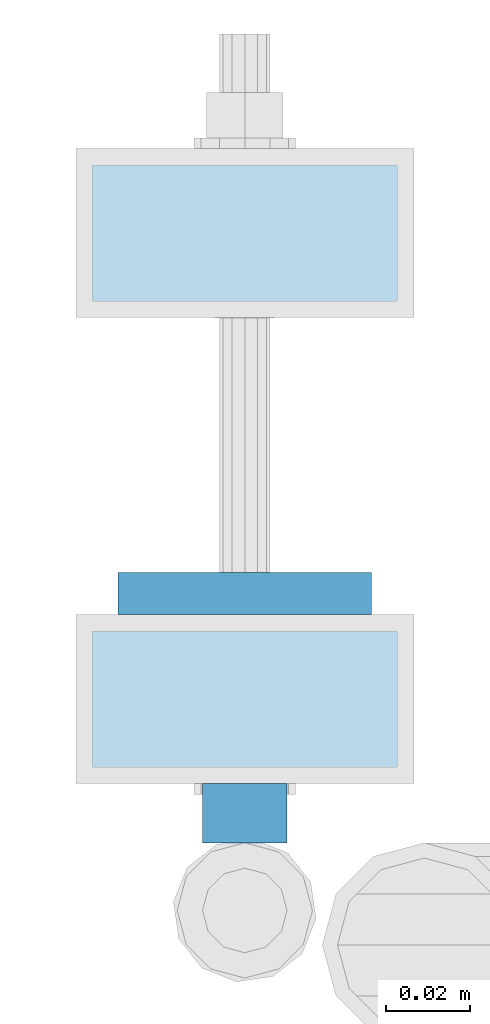
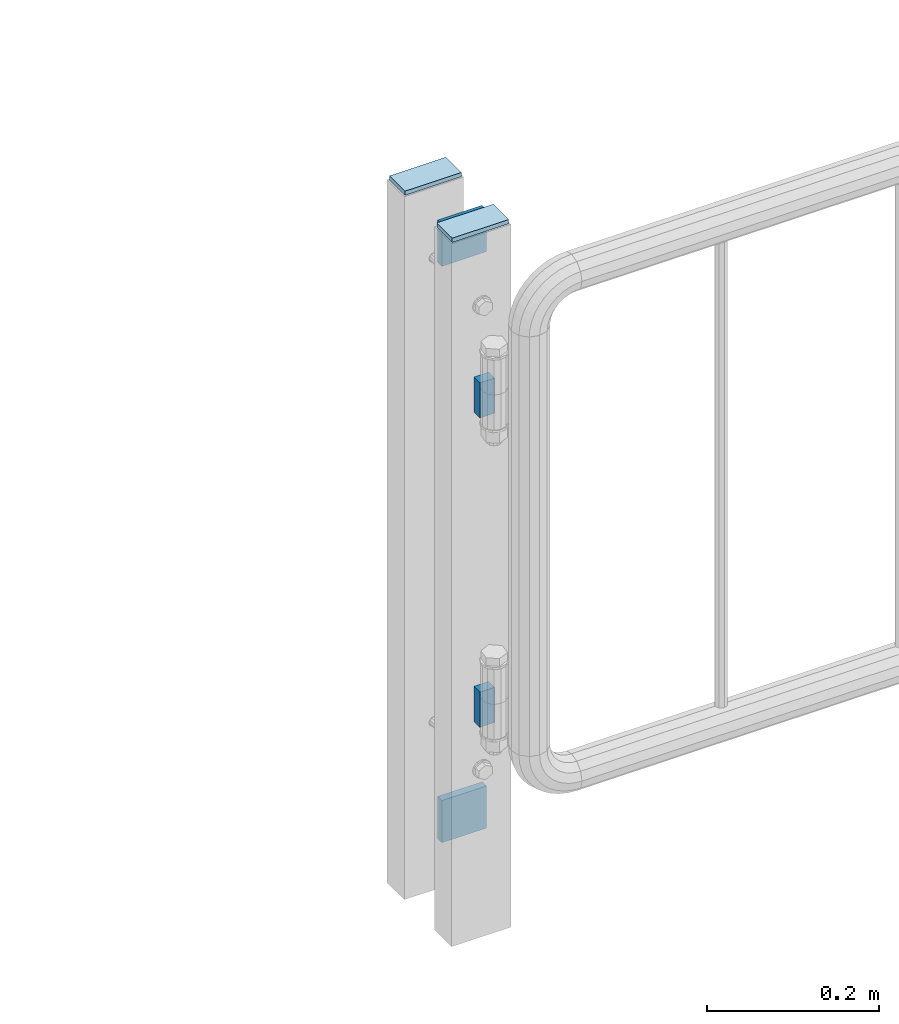
# One storey, part 263 of 270: 6 plates.
"""IFC2X3 building model written with IfcOpenShell, lengths in millimetres."""

from ifc_helpers import new_model, si_unit, frame, origin_with_axes, place, context, subcontext, project, spatial, faceted_brep, material, type_object, element, save


model = new_model("IFC2X3")

# Units and contexts
model_context = context("Model", 3, precision=1e-05, world=origin_with_axes())
body_context = subcontext(model_context, "Body", "Model", "MODEL_VIEW")
ifc_project = project(units=[si_unit("LENGTHUNIT", "METRE", prefix="MILLI"), si_unit("AREAUNIT", "SQUARE_METRE"), si_unit("VOLUMEUNIT", "CUBIC_METRE"), si_unit("MASSUNIT", "GRAM", prefix="KILO"), si_unit("TIMEUNIT", "SECOND"), si_unit("PLANEANGLEUNIT", "RADIAN"), si_unit("SOLIDANGLEUNIT", "STERADIAN"), si_unit("THERMODYNAMICTEMPERATUREUNIT", "DEGREE_CELSIUS"), si_unit("LUMINOUSINTENSITYUNIT", "LUMEN")], contexts=[model_context])

# Site, building, storey
site_placement = place(None, origin_with_axes())
site = spatial("IfcSite", under=ifc_project, at=site_placement, CompositionType="ELEMENT")
building_placement = place(site_placement, origin_with_axes())
building = spatial("IfcBuilding", under=site, at=building_placement, Name="Standard", CompositionType="ELEMENT")
storey_placement = place(building_placement, origin_with_axes())
storey = spatial("IfcBuildingStorey", under=building, at=storey_placement, Name="Undefined", CompositionType="ELEMENT", Elevation=0.0)

# Plates
ifc_material = material(Name="STEEL/S355J2")
plate_type_1 = type_object("IfcPlateType", PredefinedType="NOTDEFINED")
for number, where, z_axis, x_axis in (
    (1, (30418.7460172356, -18026.9960000038, 360.000006544458), (0.0, 0.0, -1.0), (1.0, 0.0, 0.0)),
    (2, (30418.7460172356, -18026.9960000038, 800.000006544458), (0.0, 0.0, -1.0), (1.0, 0.0, 0.0)),
):
    element("IfcPlate", number, at=place(storey_placement, frame(where, z_axis=z_axis, x_axis=x_axis)), inside=storey, type_object=plate_type_1, material=ifc_material, context=body_context, shape_type="Brep", body=[
        faceted_brep([(0.0, -7.0, 0.0), (0.0, -7.0, 50.0), (0.0, 7.0, 50.0), (0.0, 7.0, 0.0), (20.0, -7.0, 50.0), (20.0, 7.0, 50.0), (20.0, -7.0, 0.0), (20.0, 7.0, 0.0)], [[[0, 1, 2, 3]], [[1, 4, 5, 2]], [[4, 6, 7, 5]], [[6, 0, 3, 7]], [[5, 7, 3, 2]], [[6, 4, 1, 0]]]),
    ])
plate_type_2 = type_object("IfcPlateType", PredefinedType="NOTDEFINED")
for number, where, z_axis, x_axis in (
    (3, (30398.7460172356, -17974.9960000038, 180.000006544462), (0.0, 0.0, -1.0), (1.0, 0.0, 0.0)),
    (4, (30398.7460172356, -17974.9960000038, 1000.00000654446), (0.0, 0.0, -1.0), (1.0, 0.0, 0.0)),
):
    element("IfcPlate", number, at=place(storey_placement, frame(where, z_axis=z_axis, x_axis=x_axis)), inside=storey, type_object=plate_type_2, material=ifc_material, context=body_context, shape_type="Brep", body=[
        faceted_brep([(0.0, -5.0, 0.0), (0.0, -5.0, 60.0), (0.0, 5.0, 60.0), (0.0, 5.0, 0.0), (60.0, -5.0, 60.0), (60.0, 5.0, 60.0), (60.0, -5.0, 0.0), (60.0, 5.0, 0.0)], [[[0, 1, 2, 3]], [[1, 4, 5, 2]], [[4, 6, 7, 5]], [[6, 0, 3, 7]], [[5, 7, 3, 2]], [[6, 4, 1, 0]]]),
    ])
plate_type_3 = type_object("IfcPlateType", PredefinedType="NOTDEFINED")
for number, where, z_axis, x_axis in (
    (5, (30466.7460172356, -17907.6960000038, 1003.00000654446), (-1.0, 0.0, 0.0), (0.0, 1.0, 0.0)),
    (6, (30466.7460172356, -18017.9960000038, 1003.00000654446), (-1.0, 0.0, 0.0), (0.0, 1.0, 0.0)),
):
    element("IfcPlate", number, at=place(storey_placement, frame(where, z_axis=z_axis, x_axis=x_axis)), inside=storey, type_object=plate_type_3, material=ifc_material, context=body_context, shape_type="Brep", body=[
        faceted_brep([(0.0, -3.0, 0.0), (-2.35078914556652e-07, -3.0, 76.0), (-2.35078914556652e-07, 3.0, 76.0), (0.0, 3.0, 0.0), (36.0, -3.0, 76.0), (36.0, 3.0, 76.0), (36.0, -3.0, 0.0), (36.0, 3.0, 0.0)], [[[0, 1, 2, 3]], [[1, 4, 5, 2]], [[4, 6, 7, 5]], [[6, 0, 3, 7]], [[5, 7, 3, 2]], [[6, 4, 1, 0]]]),
    ])

save(model, "model.ifc")
